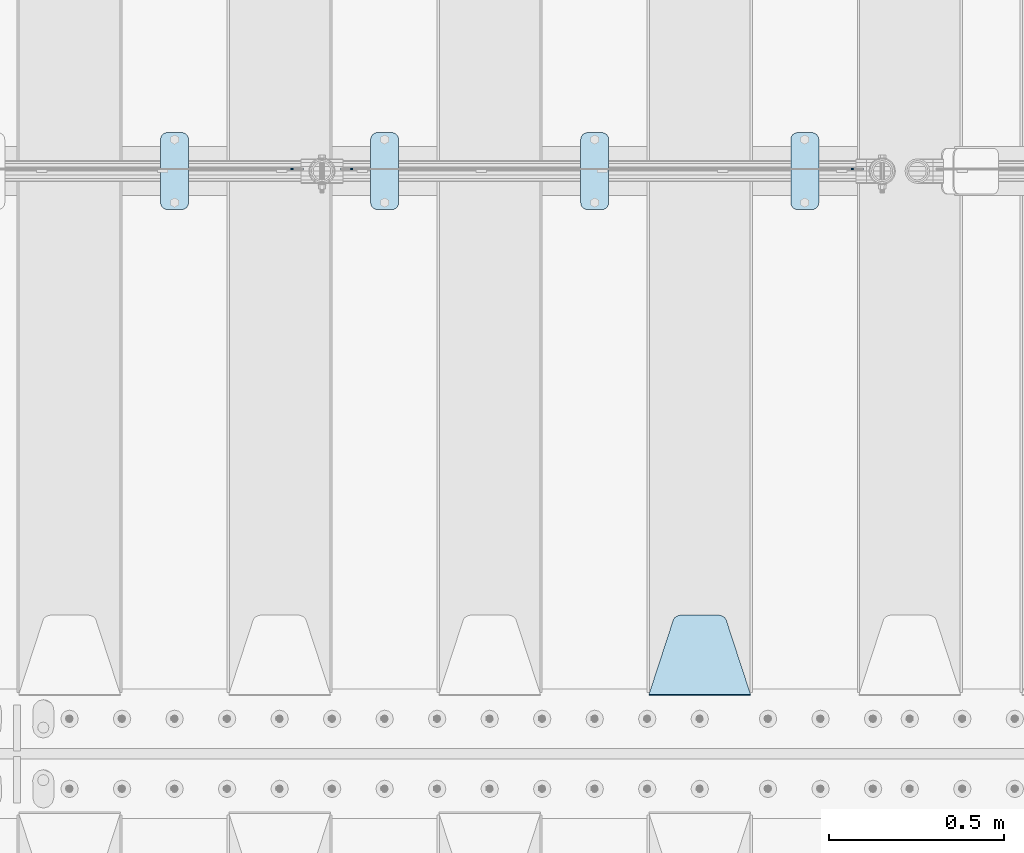
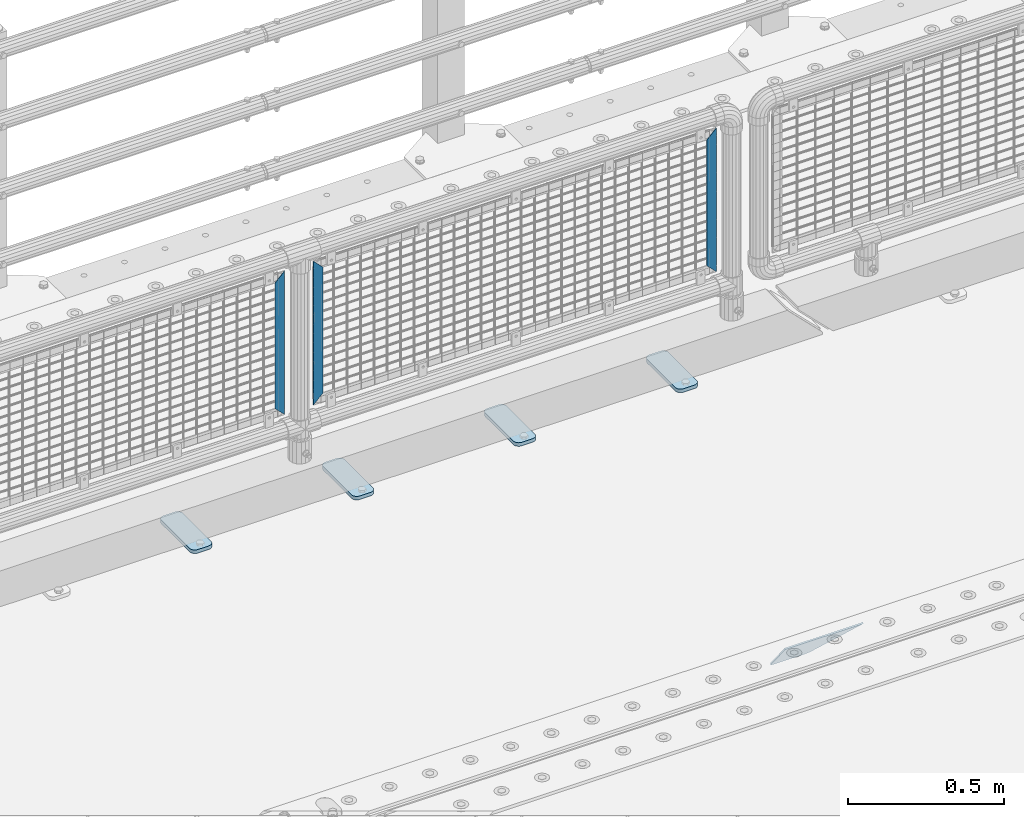
# One storey, part 185 of 208: 8 plates.
"""IFC2X3 building model written with IfcOpenShell, lengths in millimetres."""

from ifc_helpers import new_model, si_unit, frame, origin_with_axes, place, context, subcontext, project, spatial, faceted_brep, material, type_object, element, save


model = new_model("IFC2X3")

# Units and contexts
model_context = context("Model", 3, precision=1e-05, world=origin_with_axes())
body_context = subcontext(model_context, "Body", "Model", "MODEL_VIEW")
ifc_project = project(units=[si_unit("LENGTHUNIT", "METRE", prefix="MILLI"), si_unit("AREAUNIT", "SQUARE_METRE"), si_unit("VOLUMEUNIT", "CUBIC_METRE"), si_unit("MASSUNIT", "GRAM", prefix="KILO"), si_unit("TIMEUNIT", "SECOND"), si_unit("PLANEANGLEUNIT", "RADIAN"), si_unit("SOLIDANGLEUNIT", "STERADIAN"), si_unit("THERMODYNAMICTEMPERATUREUNIT", "DEGREE_CELSIUS"), si_unit("LUMINOUSINTENSITYUNIT", "LUMEN")], contexts=[model_context])

# Site, building, storey
site_placement = place(None, origin_with_axes())
site = spatial("IfcSite", under=ifc_project, at=site_placement, CompositionType="ELEMENT")
building_placement = place(site_placement, origin_with_axes())
building = spatial("IfcBuilding", under=site, at=building_placement, Name="Standard", CompositionType="ELEMENT")
storey_placement = place(building_placement, origin_with_axes())
storey = spatial("IfcBuildingStorey", under=building, at=storey_placement, Name="Undefined", CompositionType="ELEMENT", Elevation=0.0)

# Plates
ifc_material_1 = material(Name="STEEL/S355J2")
plate_type_1 = type_object("IfcPlateType", PredefinedType="NOTDEFINED")
plate_1_placement = place(storey_placement, frame((-27690.0, 4774.5, 21.0199999999977), z_axis=(1.0, 0.0, 0.0), x_axis=(0.0, -1.0, 0.0)))
element("IfcPlate", 1, at=plate_1_placement, inside=storey, type_object=plate_type_1, material=ifc_material_1, context=body_context, shape_type="Brep", body=[
    faceted_brep([(0.0, -7.0, 20.0), (0.0, -7.0, 60.0), (0.0, 7.0, 60.0), (0.0, 7.0, 20.0), (0.384294391935327, -7.0, 63.9018064403208), (0.384294391935327, 7.0, 63.9018064403208), (1.52240934977453, -7.0, 67.6536686473009), (1.52240934977453, 7.0, 67.6536686473009), (3.37060775394912, -7.0, 71.1114046603907), (3.37060775394912, 7.0, 71.1114046603907), (5.85786437626939, -7.0, 74.1421356237297), (5.85786437626939, 7.0, 74.1421356237297), (8.8885953396084, -7.0, 76.62939224605), (8.8885953396084, 7.0, 76.62939224605), (12.3463313526981, -7.0, 78.4775906502255), (12.3463313526981, 7.0, 78.4775906502255), (16.0981935596774, -7.0, 79.6157056080629), (16.0981935596774, 7.0, 79.6157056080629), (20.0, -7.0, 80.0), (20.0, 7.0, 80.0), (200.0, -7.0, 80.0), (200.0, 7.0, 80.0), (203.901806440323, -7.0, 79.6157056080629), (203.901806440323, 7.0, 79.6157056080629), (207.653668647302, -7.0, 78.4775906502255), (207.653668647302, 7.0, 78.4775906502255), (211.111404660393, -7.0, 76.62939224605), (211.111404660393, 7.0, 76.62939224605), (214.142135623731, -7.0, 74.1421356237297), (214.142135623731, 7.0, 74.1421356237297), (216.629392246051, -7.0, 71.1114046603907), (216.629392246051, 7.0, 71.1114046603907), (218.477590650225, -7.0, 67.6536686473009), (218.477590650225, 7.0, 67.6536686473009), (219.615705608065, -7.0, 63.9018064403208), (219.615705608065, 7.0, 63.9018064403208), (220.0, -7.0, 60.0), (220.0, 7.0, 60.0), (220.0, -7.0, 20.0), (220.0, 7.0, 20.0), (219.615705608065, -7.0, 16.0981935596792), (219.615705608065, 7.0, 16.0981935596792), (218.477590650225, -7.0, 12.3463313526991), (218.477590650225, 7.0, 12.3463313526991), (216.629392246051, -7.0, 8.88859533960931), (216.629392246051, 7.0, 8.88859533960931), (214.142135623731, -7.0, 5.8578643762703), (214.142135623731, 7.0, 5.8578643762703), (211.111404660393, -7.0, 3.37060775395003), (211.111404660393, 7.0, 3.37060775395003), (207.653668647302, -7.0, 1.52240934977453), (207.653668647302, 7.0, 1.52240934977453), (203.901806440323, -7.0, 0.384294391937146), (203.901806440323, 7.0, 0.384294391937146), (200.0, -7.0, 0.0), (200.0, 7.0, 0.0), (20.0, -7.0, 0.0), (20.0, 7.0, 0.0), (16.0981935596774, -7.0, 0.384294391937146), (16.0981935596774, 7.0, 0.384294391937146), (12.3463313526981, -7.0, 1.52240934977453), (12.3463313526981, 7.0, 1.52240934977453), (8.8885953396084, -7.0, 3.37060775395003), (8.8885953396084, 7.0, 3.37060775395003), (5.85786437626939, -7.0, 5.8578643762703), (5.85786437626939, 7.0, 5.8578643762703), (3.37060775394912, -7.0, 8.88859533960931), (3.37060775394912, 7.0, 8.88859533960931), (1.52240934977453, -7.0, 12.3463313526991), (1.52240934977453, 7.0, 12.3463313526991), (0.384294391935327, -7.0, 16.0981935596792), (0.384294391935327, 7.0, 16.0981935596792)], [[[0, 1, 2, 3]], [[1, 4, 5, 2]], [[4, 6, 7, 5]], [[6, 8, 9, 7]], [[8, 10, 11, 9]], [[10, 12, 13, 11]], [[12, 14, 15, 13]], [[14, 16, 17, 15]], [[16, 18, 19, 17]], [[18, 20, 21, 19]], [[20, 22, 23, 21]], [[22, 24, 25, 23]], [[24, 26, 27, 25]], [[26, 28, 29, 27]], [[28, 30, 31, 29]], [[30, 32, 33, 31]], [[32, 34, 35, 33]], [[34, 36, 37, 35]], [[36, 38, 39, 37]], [[38, 40, 41, 39]], [[40, 42, 43, 41]], [[42, 44, 45, 43]], [[44, 46, 47, 45]], [[46, 48, 49, 47]], [[48, 50, 51, 49]], [[50, 52, 53, 51]], [[52, 54, 55, 53]], [[54, 56, 57, 55]], [[56, 58, 59, 57]], [[58, 60, 61, 59]], [[60, 62, 63, 61]], [[62, 64, 65, 63]], [[64, 66, 67, 65]], [[66, 68, 69, 67]], [[68, 70, 71, 69]], [[70, 0, 3, 71]], [[5, 7, 9, 11, 13, 15, 17, 19, 21, 23, 25, 27, 29, 31, 33, 35, 37, 39, 41, 43, 45, 47, 49, 51, 53, 55, 57, 59, 61, 63, 65, 67, 69, 71, 3, 2]], [[70, 68, 66, 64, 62, 60, 58, 56, 54, 52, 50, 48, 46, 44, 42, 40, 38, 36, 34, 32, 30, 28, 26, 24, 22, 20, 18, 16, 14, 12, 10, 8, 6, 4, 1, 0]]]),
])
plate_2_placement = place(storey_placement, frame((-28290.0, 4774.5, 21.0199999999977), z_axis=(1.0, 0.0, 0.0), x_axis=(0.0, -1.0, 0.0)))
element("IfcPlate", 2, at=plate_2_placement, inside=storey, type_object=plate_type_1, material=ifc_material_1, context=body_context, shape_type="Brep", body=[
    faceted_brep([(0.0, -7.0, 20.0), (0.0, -7.0, 60.0), (0.0, 7.0, 60.0), (0.0, 7.0, 20.0), (0.384294391935327, -7.0, 63.9018064403208), (0.384294391935327, 7.0, 63.9018064403208), (1.52240934977453, -7.0, 67.6536686473009), (1.52240934977453, 7.0, 67.6536686473009), (3.37060775394912, -7.0, 71.1114046603907), (3.37060775394912, 7.0, 71.1114046603907), (5.85786437626939, -7.0, 74.1421356237297), (5.85786437626939, 7.0, 74.1421356237297), (8.8885953396084, -7.0, 76.62939224605), (8.8885953396084, 7.0, 76.62939224605), (12.3463313526981, -7.0, 78.4775906502255), (12.3463313526981, 7.0, 78.4775906502255), (16.0981935596774, -7.0, 79.6157056080629), (16.0981935596774, 7.0, 79.6157056080629), (20.0, -7.0, 80.0), (20.0, 7.0, 80.0), (200.0, -7.0, 80.0), (200.0, 7.0, 80.0), (203.901806440323, -7.0, 79.6157056080629), (203.901806440323, 7.0, 79.6157056080629), (207.653668647302, -7.0, 78.4775906502255), (207.653668647302, 7.0, 78.4775906502255), (211.111404660393, -7.0, 76.62939224605), (211.111404660393, 7.0, 76.62939224605), (214.142135623731, -7.0, 74.1421356237297), (214.142135623731, 7.0, 74.1421356237297), (216.629392246051, -7.0, 71.1114046603907), (216.629392246051, 7.0, 71.1114046603907), (218.477590650225, -7.0, 67.6536686473009), (218.477590650225, 7.0, 67.6536686473009), (219.615705608065, -7.0, 63.9018064403208), (219.615705608065, 7.0, 63.9018064403208), (220.0, -7.0, 60.0), (220.0, 7.0, 60.0), (220.0, -7.0, 20.0), (220.0, 7.0, 20.0), (219.615705608065, -7.0, 16.0981935596792), (219.615705608065, 7.0, 16.0981935596792), (218.477590650225, -7.0, 12.3463313526991), (218.477590650225, 7.0, 12.3463313526991), (216.629392246051, -7.0, 8.88859533960931), (216.629392246051, 7.0, 8.88859533960931), (214.142135623731, -7.0, 5.8578643762703), (214.142135623731, 7.0, 5.8578643762703), (211.111404660393, -7.0, 3.37060775395003), (211.111404660393, 7.0, 3.37060775395003), (207.653668647302, -7.0, 1.52240934977453), (207.653668647302, 7.0, 1.52240934977453), (203.901806440323, -7.0, 0.384294391937146), (203.901806440323, 7.0, 0.384294391937146), (200.0, -7.0, 0.0), (200.0, 7.0, 0.0), (20.0, -7.0, 0.0), (20.0, 7.0, 0.0), (16.0981935596774, -7.0, 0.384294391937146), (16.0981935596774, 7.0, 0.384294391937146), (12.3463313526981, -7.0, 1.52240934977453), (12.3463313526981, 7.0, 1.52240934977453), (8.8885953396084, -7.0, 3.37060775395003), (8.8885953396084, 7.0, 3.37060775395003), (5.85786437626939, -7.0, 5.8578643762703), (5.85786437626939, 7.0, 5.8578643762703), (3.37060775394912, -7.0, 8.88859533960931), (3.37060775394912, 7.0, 8.88859533960931), (1.52240934977453, -7.0, 12.3463313526991), (1.52240934977453, 7.0, 12.3463313526991), (0.384294391935327, -7.0, 16.0981935596792), (0.384294391935327, 7.0, 16.0981935596792)], [[[0, 1, 2, 3]], [[1, 4, 5, 2]], [[4, 6, 7, 5]], [[6, 8, 9, 7]], [[8, 10, 11, 9]], [[10, 12, 13, 11]], [[12, 14, 15, 13]], [[14, 16, 17, 15]], [[16, 18, 19, 17]], [[18, 20, 21, 19]], [[20, 22, 23, 21]], [[22, 24, 25, 23]], [[24, 26, 27, 25]], [[26, 28, 29, 27]], [[28, 30, 31, 29]], [[30, 32, 33, 31]], [[32, 34, 35, 33]], [[34, 36, 37, 35]], [[36, 38, 39, 37]], [[38, 40, 41, 39]], [[40, 42, 43, 41]], [[42, 44, 45, 43]], [[44, 46, 47, 45]], [[46, 48, 49, 47]], [[48, 50, 51, 49]], [[50, 52, 53, 51]], [[52, 54, 55, 53]], [[54, 56, 57, 55]], [[56, 58, 59, 57]], [[58, 60, 61, 59]], [[60, 62, 63, 61]], [[62, 64, 65, 63]], [[64, 66, 67, 65]], [[66, 68, 69, 67]], [[68, 70, 71, 69]], [[70, 0, 3, 71]], [[5, 7, 9, 11, 13, 15, 17, 19, 21, 23, 25, 27, 29, 31, 33, 35, 37, 39, 41, 43, 45, 47, 49, 51, 53, 55, 57, 59, 61, 63, 65, 67, 69, 71, 3, 2]], [[70, 68, 66, 64, 62, 60, 58, 56, 54, 52, 50, 48, 46, 44, 42, 40, 38, 36, 34, 32, 30, 28, 26, 24, 22, 20, 18, 16, 14, 12, 10, 8, 6, 4, 1, 0]]]),
])
plate_3_placement = place(storey_placement, frame((-28890.0, 4774.5, 21.0199999999977), z_axis=(1.0, 0.0, 0.0), x_axis=(0.0, -1.0, 0.0)))
element("IfcPlate", 3, at=plate_3_placement, inside=storey, type_object=plate_type_1, material=ifc_material_1, context=body_context, shape_type="Brep", body=[
    faceted_brep([(0.0, -7.0, 20.0), (0.0, -7.0, 60.0), (0.0, 7.0, 60.0), (0.0, 7.0, 20.0), (0.384294391935327, -7.0, 63.9018064403208), (0.384294391935327, 7.0, 63.9018064403208), (1.52240934977453, -7.0, 67.6536686473009), (1.52240934977453, 7.0, 67.6536686473009), (3.37060775394912, -7.0, 71.1114046603907), (3.37060775394912, 7.0, 71.1114046603907), (5.85786437626939, -7.0, 74.1421356237297), (5.85786437626939, 7.0, 74.1421356237297), (8.8885953396084, -7.0, 76.62939224605), (8.8885953396084, 7.0, 76.62939224605), (12.3463313526981, -7.0, 78.4775906502255), (12.3463313526981, 7.0, 78.4775906502255), (16.0981935596774, -7.0, 79.6157056080629), (16.0981935596774, 7.0, 79.6157056080629), (20.0, -7.0, 80.0), (20.0, 7.0, 80.0), (200.0, -7.0, 80.0), (200.0, 7.0, 80.0), (203.901806440323, -7.0, 79.6157056080629), (203.901806440323, 7.0, 79.6157056080629), (207.653668647302, -7.0, 78.4775906502255), (207.653668647302, 7.0, 78.4775906502255), (211.111404660393, -7.0, 76.62939224605), (211.111404660393, 7.0, 76.62939224605), (214.142135623731, -7.0, 74.1421356237297), (214.142135623731, 7.0, 74.1421356237297), (216.629392246051, -7.0, 71.1114046603907), (216.629392246051, 7.0, 71.1114046603907), (218.477590650225, -7.0, 67.6536686473009), (218.477590650225, 7.0, 67.6536686473009), (219.615705608065, -7.0, 63.9018064403208), (219.615705608065, 7.0, 63.9018064403208), (220.0, -7.0, 60.0), (220.0, 7.0, 60.0), (220.0, -7.0, 20.0), (220.0, 7.0, 20.0), (219.615705608065, -7.0, 16.0981935596792), (219.615705608065, 7.0, 16.0981935596792), (218.477590650225, -7.0, 12.3463313526991), (218.477590650225, 7.0, 12.3463313526991), (216.629392246051, -7.0, 8.88859533960931), (216.629392246051, 7.0, 8.88859533960931), (214.142135623731, -7.0, 5.8578643762703), (214.142135623731, 7.0, 5.8578643762703), (211.111404660393, -7.0, 3.37060775395003), (211.111404660393, 7.0, 3.37060775395003), (207.653668647302, -7.0, 1.52240934977453), (207.653668647302, 7.0, 1.52240934977453), (203.901806440323, -7.0, 0.384294391937146), (203.901806440323, 7.0, 0.384294391937146), (200.0, -7.0, 0.0), (200.0, 7.0, 0.0), (20.0, -7.0, 0.0), (20.0, 7.0, 0.0), (16.0981935596774, -7.0, 0.384294391937146), (16.0981935596774, 7.0, 0.384294391937146), (12.3463313526981, -7.0, 1.52240934977453), (12.3463313526981, 7.0, 1.52240934977453), (8.8885953396084, -7.0, 3.37060775395003), (8.8885953396084, 7.0, 3.37060775395003), (5.85786437626939, -7.0, 5.8578643762703), (5.85786437626939, 7.0, 5.8578643762703), (3.37060775394912, -7.0, 8.88859533960931), (3.37060775394912, 7.0, 8.88859533960931), (1.52240934977453, -7.0, 12.3463313526991), (1.52240934977453, 7.0, 12.3463313526991), (0.384294391935327, -7.0, 16.0981935596792), (0.384294391935327, 7.0, 16.0981935596792)], [[[0, 1, 2, 3]], [[1, 4, 5, 2]], [[4, 6, 7, 5]], [[6, 8, 9, 7]], [[8, 10, 11, 9]], [[10, 12, 13, 11]], [[12, 14, 15, 13]], [[14, 16, 17, 15]], [[16, 18, 19, 17]], [[18, 20, 21, 19]], [[20, 22, 23, 21]], [[22, 24, 25, 23]], [[24, 26, 27, 25]], [[26, 28, 29, 27]], [[28, 30, 31, 29]], [[30, 32, 33, 31]], [[32, 34, 35, 33]], [[34, 36, 37, 35]], [[36, 38, 39, 37]], [[38, 40, 41, 39]], [[40, 42, 43, 41]], [[42, 44, 45, 43]], [[44, 46, 47, 45]], [[46, 48, 49, 47]], [[48, 50, 51, 49]], [[50, 52, 53, 51]], [[52, 54, 55, 53]], [[54, 56, 57, 55]], [[56, 58, 59, 57]], [[58, 60, 61, 59]], [[60, 62, 63, 61]], [[62, 64, 65, 63]], [[64, 66, 67, 65]], [[66, 68, 69, 67]], [[68, 70, 71, 69]], [[70, 0, 3, 71]], [[5, 7, 9, 11, 13, 15, 17, 19, 21, 23, 25, 27, 29, 31, 33, 35, 37, 39, 41, 43, 45, 47, 49, 51, 53, 55, 57, 59, 61, 63, 65, 67, 69, 71, 3, 2]], [[70, 68, 66, 64, 62, 60, 58, 56, 54, 52, 50, 48, 46, 44, 42, 40, 38, 36, 34, 32, 30, 28, 26, 24, 22, 20, 18, 16, 14, 12, 10, 8, 6, 4, 1, 0]]]),
])
plate_4_placement = place(storey_placement, frame((-29490.0, 4774.5, 21.0199999999977), z_axis=(1.0, 0.0, 0.0), x_axis=(0.0, -1.0, 0.0)))
element("IfcPlate", 4, at=plate_4_placement, inside=storey, type_object=plate_type_1, material=ifc_material_1, context=body_context, shape_type="Brep", body=[
    faceted_brep([(0.0, -7.0, 20.0), (0.0, -7.0, 60.0), (0.0, 7.0, 60.0), (0.0, 7.0, 20.0), (0.384294391935327, -7.0, 63.9018064403208), (0.384294391935327, 7.0, 63.9018064403208), (1.52240934977453, -7.0, 67.6536686473009), (1.52240934977453, 7.0, 67.6536686473009), (3.37060775394912, -7.0, 71.1114046603907), (3.37060775394912, 7.0, 71.1114046603907), (5.85786437626939, -7.0, 74.1421356237297), (5.85786437626939, 7.0, 74.1421356237297), (8.8885953396084, -7.0, 76.62939224605), (8.8885953396084, 7.0, 76.62939224605), (12.3463313526981, -7.0, 78.4775906502255), (12.3463313526981, 7.0, 78.4775906502255), (16.0981935596774, -7.0, 79.6157056080629), (16.0981935596774, 7.0, 79.6157056080629), (20.0, -7.0, 80.0), (20.0, 7.0, 80.0), (200.0, -7.0, 80.0), (200.0, 7.0, 80.0), (203.901806440323, -7.0, 79.6157056080629), (203.901806440323, 7.0, 79.6157056080629), (207.653668647302, -7.0, 78.4775906502255), (207.653668647302, 7.0, 78.4775906502255), (211.111404660393, -7.0, 76.62939224605), (211.111404660393, 7.0, 76.62939224605), (214.142135623731, -7.0, 74.1421356237297), (214.142135623731, 7.0, 74.1421356237297), (216.629392246051, -7.0, 71.1114046603907), (216.629392246051, 7.0, 71.1114046603907), (218.477590650225, -7.0, 67.6536686473009), (218.477590650225, 7.0, 67.6536686473009), (219.615705608065, -7.0, 63.9018064403208), (219.615705608065, 7.0, 63.9018064403208), (220.0, -7.0, 60.0), (220.0, 7.0, 60.0), (220.0, -7.0, 20.0), (220.0, 7.0, 20.0), (219.615705608065, -7.0, 16.0981935596792), (219.615705608065, 7.0, 16.0981935596792), (218.477590650225, -7.0, 12.3463313526991), (218.477590650225, 7.0, 12.3463313526991), (216.629392246051, -7.0, 8.88859533960931), (216.629392246051, 7.0, 8.88859533960931), (214.142135623731, -7.0, 5.8578643762703), (214.142135623731, 7.0, 5.8578643762703), (211.111404660393, -7.0, 3.37060775395003), (211.111404660393, 7.0, 3.37060775395003), (207.653668647302, -7.0, 1.52240934977453), (207.653668647302, 7.0, 1.52240934977453), (203.901806440323, -7.0, 0.384294391937146), (203.901806440323, 7.0, 0.384294391937146), (200.0, -7.0, 0.0), (200.0, 7.0, 0.0), (20.0, -7.0, 0.0), (20.0, 7.0, 0.0), (16.0981935596774, -7.0, 0.384294391937146), (16.0981935596774, 7.0, 0.384294391937146), (12.3463313526981, -7.0, 1.52240934977453), (12.3463313526981, 7.0, 1.52240934977453), (8.8885953396084, -7.0, 3.37060775395003), (8.8885953396084, 7.0, 3.37060775395003), (5.85786437626939, -7.0, 5.8578643762703), (5.85786437626939, 7.0, 5.8578643762703), (3.37060775394912, -7.0, 8.88859533960931), (3.37060775394912, 7.0, 8.88859533960931), (1.52240934977453, -7.0, 12.3463313526991), (1.52240934977453, 7.0, 12.3463313526991), (0.384294391935327, -7.0, 16.0981935596792), (0.384294391935327, 7.0, 16.0981935596792)], [[[0, 1, 2, 3]], [[1, 4, 5, 2]], [[4, 6, 7, 5]], [[6, 8, 9, 7]], [[8, 10, 11, 9]], [[10, 12, 13, 11]], [[12, 14, 15, 13]], [[14, 16, 17, 15]], [[16, 18, 19, 17]], [[18, 20, 21, 19]], [[20, 22, 23, 21]], [[22, 24, 25, 23]], [[24, 26, 27, 25]], [[26, 28, 29, 27]], [[28, 30, 31, 29]], [[30, 32, 33, 31]], [[32, 34, 35, 33]], [[34, 36, 37, 35]], [[36, 38, 39, 37]], [[38, 40, 41, 39]], [[40, 42, 43, 41]], [[42, 44, 45, 43]], [[44, 46, 47, 45]], [[46, 48, 49, 47]], [[48, 50, 51, 49]], [[50, 52, 53, 51]], [[52, 54, 55, 53]], [[54, 56, 57, 55]], [[56, 58, 59, 57]], [[58, 60, 61, 59]], [[60, 62, 63, 61]], [[62, 64, 65, 63]], [[64, 66, 67, 65]], [[66, 68, 69, 67]], [[68, 70, 71, 69]], [[70, 0, 3, 71]], [[5, 7, 9, 11, 13, 15, 17, 19, 21, 23, 25, 27, 29, 31, 33, 35, 37, 39, 41, 43, 45, 47, 49, 51, 53, 55, 57, 59, 61, 63, 65, 67, 69, 71, 3, 2]], [[70, 68, 66, 64, 62, 60, 58, 56, 54, 52, 50, 48, 46, 44, 42, 40, 38, 36, 34, 32, 30, 28, 26, 24, 22, 20, 18, 16, 14, 12, 10, 8, 6, 4, 1, 0]]]),
])
ifc_material_2 = material(Name="STEEL/S355N")
plate_type_2 = type_object("IfcPlateType", PredefinedType="NOTDEFINED")
plate_5_placement = place(storey_placement, frame((-27805.0, 3168.23223304702, -1.76776695296758), z_axis=(0.0, 0.707106781186547, -0.707106781186548), x_axis=(-1.0, 0.0, 0.0)))
element("IfcPlate", 5, at=plate_5_placement, inside=storey, type_object=plate_type_2, material=ifc_material_2, context=body_context, shape_type="Brep", body=[
    faceted_brep([(0.0, -2.5, 0.0), (69.345504679477, -2.5, 300.17173142483), (69.345504679477, 2.5, 300.17173142483), (0.0, 2.5, 0.0), (70.9274061199576, -2.5, 304.897442415399), (70.9274061199576, 2.5, 304.8974424154), (73.3818627772307, -2.5, 309.234538108527), (73.3818627772307, 2.5, 309.234538108527), (76.6187032999551, -2.5, 313.023683126103), (76.6187032999551, 2.5, 313.023683126103), (80.5190132704993, -2.5, 316.125672595371), (80.5190132704993, 2.5, 316.125672595371), (84.9395038596849, -2.5, 318.426546230476), (84.9395038596849, 2.50000000000091, 318.426546230476), (89.7177759439219, -2.5, 319.841774983275), (89.7177759439219, 2.50000000000091, 319.841774983275), (94.678286292652, -2.49999999999909, 320.319366455078), (94.678286292652, 2.5, 320.319366455078), (195.321713707348, -2.49999999999909, 320.319366455078), (195.321713707348, 2.5, 320.319366455078), (200.282224056078, -2.5, 319.841774983275), (200.282224056078, 2.5, 319.841774983274), (205.060496140315, -2.5, 318.426546230475), (205.060496140315, 2.5, 318.426546230475), (209.480986729501, -2.5, 316.125672595371), (209.480986729501, 2.50000000000091, 316.125672595371), (213.381296700045, -2.5, 313.023683126102), (213.381296700045, 2.5, 313.023683126102), (216.618137222769, -2.5, 309.234538108526), (216.618137222769, 2.5, 309.234538108527), (219.072593880042, -2.5, 304.897442415399), (219.072593880042, 2.5, 304.897442415399), (220.654495320523, -2.5, 300.17173142483), (220.654495320523, 2.5, 300.17173142483), (290.0, -2.5, 0.0), (290.0, 2.5, 0.0)], [[[0, 1, 2, 3]], [[1, 4, 5, 2]], [[4, 6, 7, 5]], [[6, 8, 9, 7]], [[8, 10, 11, 9]], [[10, 12, 13, 11]], [[12, 14, 15, 13]], [[14, 16, 17, 15]], [[16, 18, 19, 17]], [[18, 20, 21, 19]], [[20, 22, 23, 21]], [[22, 24, 25, 23]], [[24, 26, 27, 25]], [[26, 28, 29, 27]], [[28, 30, 31, 29]], [[30, 32, 33, 31]], [[32, 34, 35, 33]], [[34, 0, 3, 35]], [[5, 7, 9, 11, 13, 15, 17, 19, 21, 23, 25, 27, 29, 31, 33, 35, 3, 2]], [[34, 32, 30, 28, 26, 24, 22, 20, 18, 16, 14, 12, 10, 8, 6, 4, 1, 0]]]),
])
ifc_material_3 = material(Name="Misc_Undefined")
plate_type_3 = type_object("IfcPlateType", PredefinedType="NOTDEFINED")
plate_6_placement = place(storey_placement, frame((-28940.490286459, 4670.5, 879.519963133601), z_axis=(-0.707008801899319, 0.0, -0.707204746899291), x_axis=(-0.70720474689929, 0.0, 0.707008801899319)))
element("IfcPlate", 6, at=plate_6_placement, inside=storey, type_object=plate_type_3, material=ifc_material_3, context=body_context, shape_type="Brep", body=[
    faceted_brep([(0.0, -1.49999999999909, 3.63797880709171e-12), (-348.55218505859, -1.5, 348.655029296875), (-348.55218505859, 1.5, 348.655029296875), (0.0, 1.50000000000182, 3.63797880709171e-12), (-348.544891357418, -1.5, 398.152496337894), (-348.544891357418, 1.5, 398.152496337894), (49.5043945312536, -1.5, 7.6397554948926e-11), (49.5043945312536, 1.5, 7.6397554948926e-11)], [[[0, 1, 2, 3]], [[1, 4, 5, 2]], [[4, 6, 7, 5]], [[6, 0, 3, 7]], [[5, 7, 3, 2]], [[6, 4, 1, 0]]]),
])
for number, where, z_axis, x_axis in (
    (7, (-27517.5003125164, 4670.5, 879.52), (0.707103624179499, 0.0, -0.707109938179501), (0.707109938179495, 0.0, 0.707103624179505)),
    (8, (-29117.5003125164, 4670.5, 879.52), (0.707103624179499, 0.0, -0.707109938179501), (0.707109938179495, 0.0, 0.707103624179505)),
):
    element("IfcPlate", number, at=place(storey_placement, frame(where, z_axis=z_axis, x_axis=x_axis)), inside=storey, type_object=plate_type_3, material=ifc_material_3, context=body_context, shape_type="Brep", body=[
        faceted_brep([(0.0, -1.49999999999909, 3.63797880709171e-12), (-348.605163574219, -1.5, 348.602081298821), (-348.605163574219, 1.5, 348.602081298821), (0.0, 1.50000000000182, 3.63797880709171e-12), (-348.605163574219, -1.5, 398.099334716793), (-348.605163574219, 1.5, 398.099334716793), (49.4976959228516, -1.5, 6.91215973347425e-11), (49.4976959228516, 1.5, 6.91215973347425e-11)], [[[0, 1, 2, 3]], [[1, 4, 5, 2]], [[4, 6, 7, 5]], [[6, 0, 3, 7]], [[5, 7, 3, 2]], [[6, 4, 1, 0]]]),
    ])

save(model, "model.ifc")
